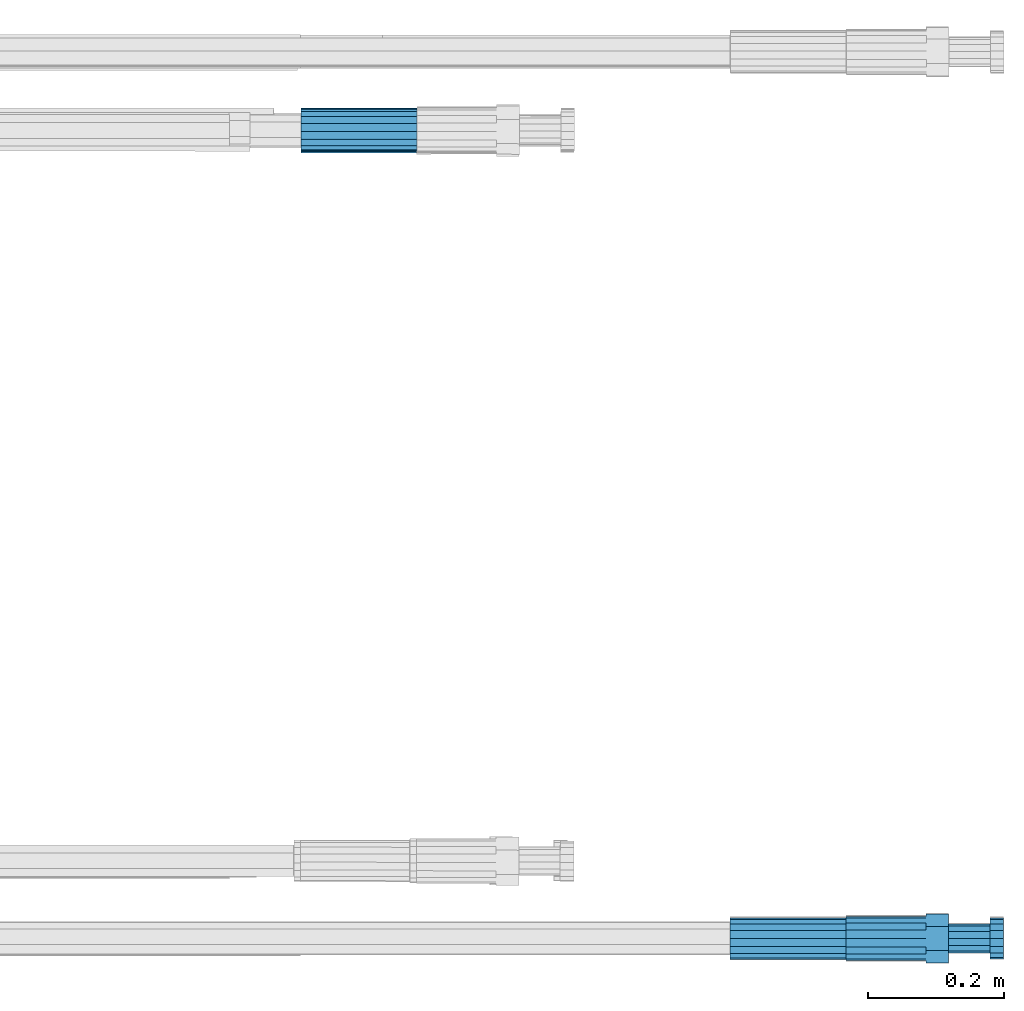
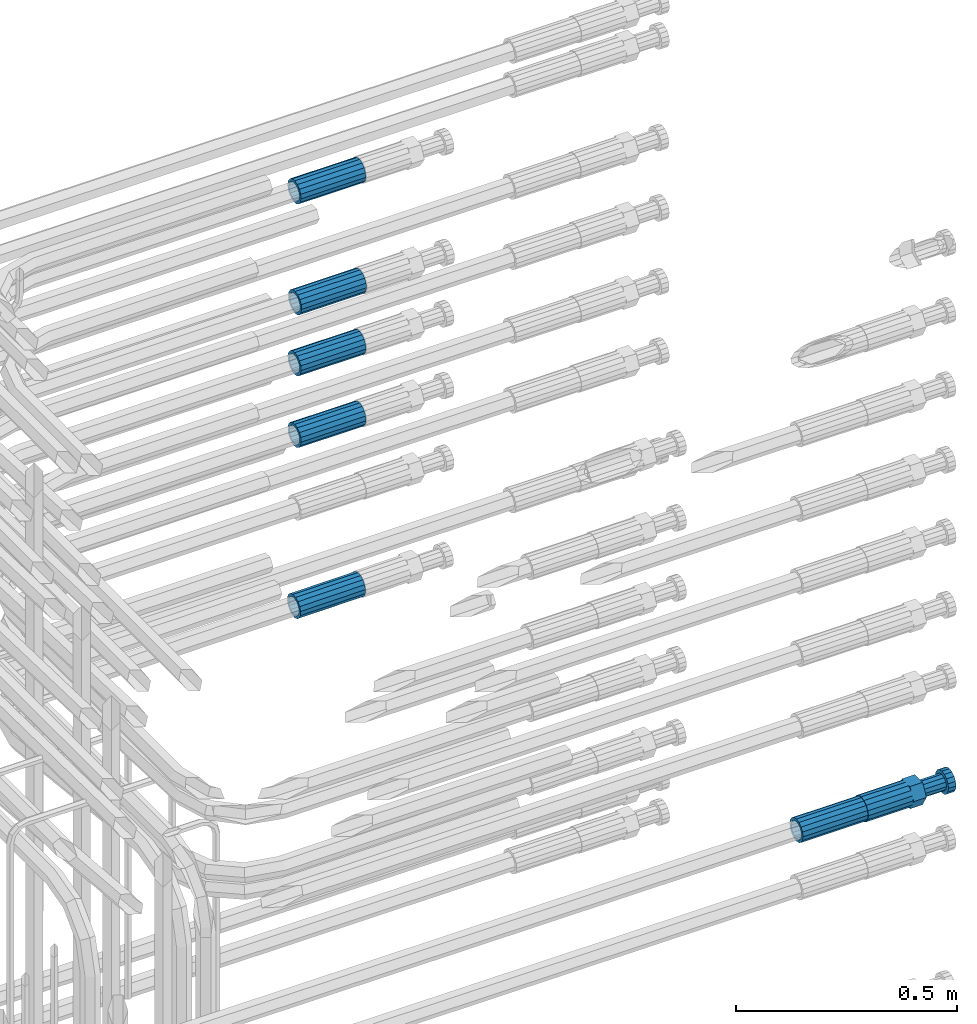
# One storey, part 107 of 177: 7 beams.
"""IFC2X3 building model written with IfcOpenShell, lengths in millimetres."""

from ifc_helpers import new_model, si_unit, frame, origin_with_axes, place, context, subcontext, project, spatial, faceted_brep, material, type_object, element, save


model = new_model("IFC2X3")

# Units and contexts
model_context_1 = context("Model", 3, precision=1e-05, world=origin_with_axes())
model_context_2 = context("Model", 3, precision=1e-05, world=origin_with_axes())
body_context = subcontext(model_context_2, "Body", "Model", "MODEL_VIEW")
ifc_project = project(units=[si_unit("LENGTHUNIT", "METRE", prefix="MILLI"), si_unit("AREAUNIT", "SQUARE_METRE"), si_unit("VOLUMEUNIT", "CUBIC_METRE"), si_unit("MASSUNIT", "GRAM", prefix="KILO"), si_unit("TIMEUNIT", "SECOND"), si_unit("PLANEANGLEUNIT", "RADIAN"), si_unit("SOLIDANGLEUNIT", "STERADIAN"), si_unit("THERMODYNAMICTEMPERATUREUNIT", "DEGREE_CELSIUS"), si_unit("LUMINOUSINTENSITYUNIT", "LUMEN")], contexts=[model_context_1])

# Site, building, storey
site_placement = place(None, origin_with_axes())
site = spatial("IfcSite", under=ifc_project, at=site_placement, CompositionType="ELEMENT")
building_placement = place(site_placement, origin_with_axes())
building = spatial("IfcBuilding", under=site, at=building_placement, Name="Undefined", CompositionType="ELEMENT")
storey_placement = place(building_placement, origin_with_axes())
storey = spatial("IfcBuildingStorey", under=building, at=storey_placement, Name="Undefined", CompositionType="ELEMENT", Elevation=0.0)

# Beams
ifc_material = material(Name="STEEL/S275")
beam_type_1 = type_object("IfcBeamType", PredefinedType="NOTDEFINED")
beam_1_placement = place(storey_placement, frame((2038719.59065702, 6206286.93900969, 19591.9562850024), z_axis=(0.00670106354495501, -0.109590881040318, -0.993954191369086), x_axis=(0.999977413945273, 0.000220438997534024, 0.00671736599963343)))
element("IfcBeam", 1, at=beam_1_placement, inside=storey, type_object=beam_type_1, material=ifc_material, Name="AG40N", context=body_context, shape_type="Brep", body=[
    faceted_brep([(0.0, -23.5000000001164, -9.31322574615479e-10), (0.0, -21.7111690140155, 8.99306066054851), (170.0, -21.7111690140155, 8.99306066054851), (170.0, -23.5, 0.0), (0.0, -16.6170093578839, 16.6170093575493), (170.0, -16.6170093578839, 16.6170093575493), (0.0, -8.99306066057943, 21.7111690137535), (170.0, -8.99306066057943, 21.7111690137535), (0.0, 1.16415321826935e-10, 23.5), (170.0, 0.0, 23.5), (0.0, 8.99306066057943, 21.7111690137535), (170.0, 8.99306066057943, 21.7111690137535), (0.0, 16.6170093578839, 16.6170093575493), (170.0, 16.6170093578839, 16.6170093575493), (0.0, 21.7111690140155, 8.99306066054851), (170.0, 21.7111690140155, 8.99306066054851), (0.0, 23.5000000001164, -9.31322574615479e-10), (170.0, 23.5, 0.0), (0.0, 21.7111690140155, -8.99306066054851), (170.0, 21.7111690140155, -8.99306066054851), (0.0, 16.6170093578839, -16.6170093575493), (170.0, 16.6170093578839, -16.6170093575493), (0.0, 8.99306066057943, -21.7111690137535), (170.0, 8.99306066057943, -21.7111690137535), (0.0, 1.16415321826935e-10, -23.5000000009313), (170.0, 0.0, -23.5), (0.0, -8.99306066057943, -21.7111690137535), (170.0, -8.99306066057943, -21.7111690137535), (0.0, -16.6170093578839, -16.6170093575493), (170.0, -16.6170093578839, -16.6170093575493), (0.0, -21.7111690140155, -8.99306066054851), (170.0, -21.7111690140155, -8.99306066054851), (0.0, -30.5, 0.0), (0.0, -28.1783257415937, -11.6718446873128), (170.0, -28.1783257415937, -11.6718446873128), (170.0, -30.5, 0.0), (0.0, -21.5667568261888, -21.5667568258941), (170.0, -21.5667568261888, -21.5667568258941), (0.0, -11.6718446871346, -28.1783257415518), (170.0, -11.6718446871346, -28.1783257415518), (0.0, 0.0, -30.5), (170.0, 0.0, -30.5), (0.0, 11.6718446871346, -28.1783257415518), (170.0, 11.6718446871346, -28.1783257415518), (0.0, 21.5667568261888, -21.5667568258941), (170.0, 21.5667568261888, -21.5667568258941), (0.0, 28.1783257415937, -11.6718446873128), (170.0, 28.1783257415937, -11.6718446873128), (0.0, 30.5, 0.0), (170.0, 30.5, 0.0), (0.0, 28.1783257415937, 11.6718446873128), (170.0, 28.1783257415937, 11.6718446873128), (0.0, 21.5667568261888, 21.5667568258941), (170.0, 21.5667568261888, 21.5667568258941), (0.0, 11.6718446871346, 28.1783257415518), (170.0, 11.6718446871346, 28.1783257415518), (0.0, 0.0, 30.5), (170.0, 0.0, 30.5), (0.0, -11.6718446871346, 28.1783257415518), (170.0, -11.6718446871346, 28.1783257415518), (0.0, -21.5667568261888, 21.5667568258941), (170.0, -21.5667568261888, 21.5667568258941), (0.0, -28.1783257415937, 11.6718446873128), (170.0, -28.1783257415937, 11.6718446873128)], [[[0, 1, 2, 3]], [[1, 4, 5, 2]], [[4, 6, 7, 5]], [[6, 8, 9, 7]], [[8, 10, 11, 9]], [[10, 12, 13, 11]], [[12, 14, 15, 13]], [[14, 16, 17, 15]], [[16, 18, 19, 17]], [[18, 20, 21, 19]], [[20, 22, 23, 21]], [[22, 24, 25, 23]], [[24, 26, 27, 25]], [[26, 28, 29, 27]], [[28, 30, 31, 29]], [[30, 0, 3, 31]], [[32, 33, 34, 35]], [[33, 36, 37, 34]], [[36, 38, 39, 37]], [[38, 40, 41, 39]], [[40, 42, 43, 41]], [[42, 44, 45, 43]], [[44, 46, 47, 45]], [[46, 48, 49, 47]], [[48, 50, 51, 49]], [[50, 52, 53, 51]], [[52, 54, 55, 53]], [[54, 56, 57, 55]], [[56, 58, 59, 57]], [[58, 60, 61, 59]], [[60, 62, 63, 61]], [[62, 32, 35, 63]], [[37, 39, 41, 43, 45, 47, 49, 51, 53, 55, 57, 59, 61, 63, 35, 34], [5, 7, 9, 11, 13, 15, 17, 19, 21, 23, 25, 27, 29, 31, 3, 2]], [[62, 60, 58, 56, 54, 52, 50, 48, 46, 44, 42, 40, 38, 36, 33, 32], [30, 28, 26, 24, 22, 20, 18, 16, 14, 12, 10, 8, 6, 4, 1, 0]]]),
])
beam_2_placement = place(storey_placement, frame((2038719.51807103, 6206284.99452423, 20740.8782264994), z_axis=(0.000401818353682753, 0.0766636489927762, -0.997056930904712), x_axis=(0.99999965876512, -0.000750492002025629, 0.000345298999912415)))
element("IfcBeam", 2, at=beam_2_placement, inside=storey, type_object=beam_type_1, material=ifc_material, Name="AG40N", context=body_context, shape_type="Brep", body=[
    faceted_brep([(0.0, -23.5000000001164, -9.31322574615479e-10), (0.0, -21.7111690140155, 8.99306066054851), (170.0, -21.7111690140155, 8.99306066054851), (170.0, -23.5, 0.0), (0.0, -16.6170093578839, 16.6170093575493), (170.0, -16.6170093578839, 16.6170093575493), (0.0, -8.99306066057943, 21.7111690137535), (170.0, -8.99306066057943, 21.7111690137535), (0.0, 1.16415321826935e-10, 23.5), (170.0, 0.0, 23.5), (0.0, 8.99306066057943, 21.7111690137535), (170.0, 8.99306066057943, 21.7111690137535), (0.0, 16.6170093578839, 16.6170093575493), (170.0, 16.6170093578839, 16.6170093575493), (0.0, 21.7111690140155, 8.99306066054851), (170.0, 21.7111690140155, 8.99306066054851), (0.0, 23.5000000001164, -9.31322574615479e-10), (170.0, 23.5, 0.0), (0.0, 21.7111690140155, -8.99306066054851), (170.0, 21.7111690140155, -8.99306066054851), (0.0, 16.6170093578839, -16.6170093575493), (170.0, 16.6170093578839, -16.6170093575493), (0.0, 8.99306066057943, -21.7111690137535), (170.0, 8.99306066057943, -21.7111690137535), (0.0, 1.16415321826935e-10, -23.5000000009313), (170.0, 0.0, -23.5), (0.0, -8.99306066057943, -21.7111690137535), (170.0, -8.99306066057943, -21.7111690137535), (0.0, -16.6170093578839, -16.6170093575493), (170.0, -16.6170093578839, -16.6170093575493), (0.0, -21.7111690140155, -8.99306066054851), (170.0, -21.7111690140155, -8.99306066054851), (0.0, -30.5, 0.0), (0.0, -28.1783257415937, -11.6718446873128), (170.0, -28.1783257415937, -11.6718446873128), (170.0, -30.5, 0.0), (0.0, -21.5667568261888, -21.5667568258941), (170.0, -21.5667568261888, -21.5667568258941), (0.0, -11.6718446871346, -28.1783257415518), (170.0, -11.6718446871346, -28.1783257415518), (0.0, 0.0, -30.5), (170.0, 0.0, -30.5), (0.0, 11.6718446871346, -28.1783257415518), (170.0, 11.6718446871346, -28.1783257415518), (0.0, 21.5667568261888, -21.5667568258941), (170.0, 21.5667568261888, -21.5667568258941), (0.0, 28.1783257415937, -11.6718446873128), (170.0, 28.1783257415937, -11.6718446873128), (0.0, 30.5, 0.0), (170.0, 30.5, 0.0), (0.0, 28.1783257415937, 11.6718446873128), (170.0, 28.1783257415937, 11.6718446873128), (0.0, 21.5667568261888, 21.5667568258941), (170.0, 21.5667568261888, 21.5667568258941), (0.0, 11.6718446871346, 28.1783257415518), (170.0, 11.6718446871346, 28.1783257415518), (0.0, 0.0, 30.5), (170.0, 0.0, 30.5), (0.0, -11.6718446871346, 28.1783257415518), (170.0, -11.6718446871346, 28.1783257415518), (0.0, -21.5667568261888, 21.5667568258941), (170.0, -21.5667568261888, 21.5667568258941), (0.0, -28.1783257415937, 11.6718446873128), (170.0, -28.1783257415937, 11.6718446873128)], [[[0, 1, 2, 3]], [[1, 4, 5, 2]], [[4, 6, 7, 5]], [[6, 8, 9, 7]], [[8, 10, 11, 9]], [[10, 12, 13, 11]], [[12, 14, 15, 13]], [[14, 16, 17, 15]], [[16, 18, 19, 17]], [[18, 20, 21, 19]], [[20, 22, 23, 21]], [[22, 24, 25, 23]], [[24, 26, 27, 25]], [[26, 28, 29, 27]], [[28, 30, 31, 29]], [[30, 0, 3, 31]], [[32, 33, 34, 35]], [[33, 36, 37, 34]], [[36, 38, 39, 37]], [[38, 40, 41, 39]], [[40, 42, 43, 41]], [[42, 44, 45, 43]], [[44, 46, 47, 45]], [[46, 48, 49, 47]], [[48, 50, 51, 49]], [[50, 52, 53, 51]], [[52, 54, 55, 53]], [[54, 56, 57, 55]], [[56, 58, 59, 57]], [[58, 60, 61, 59]], [[60, 62, 63, 61]], [[62, 32, 35, 63]], [[37, 39, 41, 43, 45, 47, 49, 51, 53, 55, 57, 59, 61, 63, 35, 34], [5, 7, 9, 11, 13, 15, 17, 19, 21, 23, 25, 27, 29, 31, 3, 2]], [[62, 60, 58, 56, 54, 52, 50, 48, 46, 44, 42, 40, 38, 36, 33, 32], [30, 28, 26, 24, 22, 20, 18, 16, 14, 12, 10, 8, 6, 4, 1, 0]]]),
])
beam_3_placement = place(storey_placement, frame((2038719.51584447, 6206284.25478352, 20067.1623282997), z_axis=(0.0, 0.0505929410066467, -0.998719357137078), x_axis=(1.0, 0.0, 0.0)))
element("IfcBeam", 3, at=beam_3_placement, inside=storey, type_object=beam_type_1, material=ifc_material, Name="AG40N", context=body_context, shape_type="Brep", body=[
    faceted_brep([(0.0, -23.5000000001164, -9.31322574615479e-10), (0.0, -21.7111690140155, 8.99306066054851), (170.0, -21.7111690140155, 8.99306066054851), (170.0, -23.5, 0.0), (0.0, -16.6170093578839, 16.6170093575493), (170.0, -16.6170093578839, 16.6170093575493), (0.0, -8.99306066057943, 21.7111690137535), (170.0, -8.99306066057943, 21.7111690137535), (0.0, 1.16415321826935e-10, 23.5), (170.0, 0.0, 23.5), (0.0, 8.99306066057943, 21.7111690137535), (170.0, 8.99306066057943, 21.7111690137535), (0.0, 16.6170093578839, 16.6170093575493), (170.0, 16.6170093578839, 16.6170093575493), (0.0, 21.7111690140155, 8.99306066054851), (170.0, 21.7111690140155, 8.99306066054851), (0.0, 23.5000000001164, -9.31322574615479e-10), (170.0, 23.5, 0.0), (0.0, 21.7111690140155, -8.99306066054851), (170.0, 21.7111690140155, -8.99306066054851), (0.0, 16.6170093578839, -16.6170093575493), (170.0, 16.6170093578839, -16.6170093575493), (0.0, 8.99306066057943, -21.7111690137535), (170.0, 8.99306066057943, -21.7111690137535), (0.0, 1.16415321826935e-10, -23.5000000009313), (170.0, 0.0, -23.5), (0.0, -8.99306066057943, -21.7111690137535), (170.0, -8.99306066057943, -21.7111690137535), (0.0, -16.6170093578839, -16.6170093575493), (170.0, -16.6170093578839, -16.6170093575493), (0.0, -21.7111690140155, -8.99306066054851), (170.0, -21.7111690140155, -8.99306066054851), (0.0, -30.5, 0.0), (0.0, -28.1783257415937, -11.6718446873128), (170.0, -28.1783257415937, -11.6718446873128), (170.0, -30.5, 0.0), (0.0, -21.5667568261888, -21.5667568258941), (170.0, -21.5667568261888, -21.5667568258941), (0.0, -11.6718446871346, -28.1783257415518), (170.0, -11.6718446871346, -28.1783257415518), (0.0, 0.0, -30.5), (170.0, 0.0, -30.5), (0.0, 11.6718446871346, -28.1783257415518), (170.0, 11.6718446871346, -28.1783257415518), (0.0, 21.5667568261888, -21.5667568258941), (170.0, 21.5667568261888, -21.5667568258941), (0.0, 28.1783257415937, -11.6718446873128), (170.0, 28.1783257415937, -11.6718446873128), (0.0, 30.5, 0.0), (170.0, 30.5, 0.0), (0.0, 28.1783257415937, 11.6718446873128), (170.0, 28.1783257415937, 11.6718446873128), (0.0, 21.5667568261888, 21.5667568258941), (170.0, 21.5667568261888, 21.5667568258941), (0.0, 11.6718446871346, 28.1783257415518), (170.0, 11.6718446871346, 28.1783257415518), (0.0, 0.0, 30.5), (170.0, 0.0, 30.5), (0.0, -11.6718446871346, 28.1783257415518), (170.0, -11.6718446871346, 28.1783257415518), (0.0, -21.5667568261888, 21.5667568258941), (170.0, -21.5667568261888, 21.5667568258941), (0.0, -28.1783257415937, 11.6718446873128), (170.0, -28.1783257415937, 11.6718446873128)], [[[0, 1, 2, 3]], [[1, 4, 5, 2]], [[4, 6, 7, 5]], [[6, 8, 9, 7]], [[8, 10, 11, 9]], [[10, 12, 13, 11]], [[12, 14, 15, 13]], [[14, 16, 17, 15]], [[16, 18, 19, 17]], [[18, 20, 21, 19]], [[20, 22, 23, 21]], [[22, 24, 25, 23]], [[24, 26, 27, 25]], [[26, 28, 29, 27]], [[28, 30, 31, 29]], [[30, 0, 3, 31]], [[32, 33, 34, 35]], [[33, 36, 37, 34]], [[36, 38, 39, 37]], [[38, 40, 41, 39]], [[40, 42, 43, 41]], [[42, 44, 45, 43]], [[44, 46, 47, 45]], [[46, 48, 49, 47]], [[48, 50, 51, 49]], [[50, 52, 53, 51]], [[52, 54, 55, 53]], [[54, 56, 57, 55]], [[56, 58, 59, 57]], [[58, 60, 61, 59]], [[60, 62, 63, 61]], [[62, 32, 35, 63]], [[37, 39, 41, 43, 45, 47, 49, 51, 53, 55, 57, 59, 61, 63, 35, 34], [5, 7, 9, 11, 13, 15, 17, 19, 21, 23, 25, 27, 29, 31, 3, 2]], [[62, 60, 58, 56, 54, 52, 50, 48, 46, 44, 42, 40, 38, 36, 33, 32], [30, 28, 26, 24, 22, 20, 18, 16, 14, 12, 10, 8, 6, 4, 1, 0]]]),
])
beam_4_placement = place(storey_placement, frame((2038719.27268514, 6206281.63885606, 20436.1870435576), z_axis=(0.00101999019715003, 0.0419084800034758, -0.999120933082575), x_axis=(0.999999429542936, 0.000274046000794836, 0.00103238199952223)))
element("IfcBeam", 4, at=beam_4_placement, inside=storey, type_object=beam_type_1, material=ifc_material, Name="AG40N", context=body_context, shape_type="Brep", body=[
    faceted_brep([(0.0, -23.5000000001164, -9.31322574615479e-10), (0.0, -21.7111690140155, 8.99306066054851), (170.0, -21.7111690140155, 8.99306066054851), (170.0, -23.5, 0.0), (0.0, -16.6170093578839, 16.6170093575493), (170.0, -16.6170093578839, 16.6170093575493), (0.0, -8.99306066057943, 21.7111690137535), (170.0, -8.99306066057943, 21.7111690137535), (0.0, 1.16415321826935e-10, 23.5), (170.0, 0.0, 23.5), (0.0, 8.99306066057943, 21.7111690137535), (170.0, 8.99306066057943, 21.7111690137535), (0.0, 16.6170093578839, 16.6170093575493), (170.0, 16.6170093578839, 16.6170093575493), (0.0, 21.7111690140155, 8.99306066054851), (170.0, 21.7111690140155, 8.99306066054851), (0.0, 23.5000000001164, -9.31322574615479e-10), (170.0, 23.5, 0.0), (0.0, 21.7111690140155, -8.99306066054851), (170.0, 21.7111690140155, -8.99306066054851), (0.0, 16.6170093578839, -16.6170093575493), (170.0, 16.6170093578839, -16.6170093575493), (0.0, 8.99306066057943, -21.7111690137535), (170.0, 8.99306066057943, -21.7111690137535), (0.0, 1.16415321826935e-10, -23.5000000009313), (170.0, 0.0, -23.5), (0.0, -8.99306066057943, -21.7111690137535), (170.0, -8.99306066057943, -21.7111690137535), (0.0, -16.6170093578839, -16.6170093575493), (170.0, -16.6170093578839, -16.6170093575493), (0.0, -21.7111690140155, -8.99306066054851), (170.0, -21.7111690140155, -8.99306066054851), (0.0, -30.5, 0.0), (0.0, -28.1783257415937, -11.6718446873128), (170.0, -28.1783257415937, -11.6718446873128), (170.0, -30.5, 0.0), (0.0, -21.5667568261888, -21.5667568258941), (170.0, -21.5667568261888, -21.5667568258941), (0.0, -11.6718446871346, -28.1783257415518), (170.0, -11.6718446871346, -28.1783257415518), (0.0, 0.0, -30.5), (170.0, 0.0, -30.5), (0.0, 11.6718446871346, -28.1783257415518), (170.0, 11.6718446871346, -28.1783257415518), (0.0, 21.5667568261888, -21.5667568258941), (170.0, 21.5667568261888, -21.5667568258941), (0.0, 28.1783257415937, -11.6718446873128), (170.0, 28.1783257415937, -11.6718446873128), (0.0, 30.5, 0.0), (170.0, 30.5, 0.0), (0.0, 28.1783257415937, 11.6718446873128), (170.0, 28.1783257415937, 11.6718446873128), (0.0, 21.5667568261888, 21.5667568258941), (170.0, 21.5667568261888, 21.5667568258941), (0.0, 11.6718446871346, 28.1783257415518), (170.0, 11.6718446871346, 28.1783257415518), (0.0, 0.0, 30.5), (170.0, 0.0, 30.5), (0.0, -11.6718446871346, 28.1783257415518), (170.0, -11.6718446871346, 28.1783257415518), (0.0, -21.5667568261888, 21.5667568258941), (170.0, -21.5667568261888, 21.5667568258941), (0.0, -28.1783257415937, 11.6718446873128), (170.0, -28.1783257415937, 11.6718446873128)], [[[0, 1, 2, 3]], [[1, 4, 5, 2]], [[4, 6, 7, 5]], [[6, 8, 9, 7]], [[8, 10, 11, 9]], [[10, 12, 13, 11]], [[12, 14, 15, 13]], [[14, 16, 17, 15]], [[16, 18, 19, 17]], [[18, 20, 21, 19]], [[20, 22, 23, 21]], [[22, 24, 25, 23]], [[24, 26, 27, 25]], [[26, 28, 29, 27]], [[28, 30, 31, 29]], [[30, 0, 3, 31]], [[32, 33, 34, 35]], [[33, 36, 37, 34]], [[36, 38, 39, 37]], [[38, 40, 41, 39]], [[40, 42, 43, 41]], [[42, 44, 45, 43]], [[44, 46, 47, 45]], [[46, 48, 49, 47]], [[48, 50, 51, 49]], [[50, 52, 53, 51]], [[52, 54, 55, 53]], [[54, 56, 57, 55]], [[56, 58, 59, 57]], [[58, 60, 61, 59]], [[60, 62, 63, 61]], [[62, 32, 35, 63]], [[37, 39, 41, 43, 45, 47, 49, 51, 53, 55, 57, 59, 61, 63, 35, 34], [5, 7, 9, 11, 13, 15, 17, 19, 21, 23, 25, 27, 29, 31, 3, 2]], [[62, 60, 58, 56, 54, 52, 50, 48, 46, 44, 42, 40, 38, 36, 33, 32], [30, 28, 26, 24, 22, 20, 18, 16, 14, 12, 10, 8, 6, 4, 1, 0]]]),
])
beam_5_placement = place(storey_placement, frame((2038719.51584447, 6206284.40860386, 20265.444592741), z_axis=(0.0, 0.0523359569851309, -0.998629534715678), x_axis=(1.0, 0.0, 0.0)))
element("IfcBeam", 5, at=beam_5_placement, inside=storey, type_object=beam_type_1, material=ifc_material, Name="AG40N", context=body_context, shape_type="Brep", body=[
    faceted_brep([(0.0, -23.5000000001164, -9.31322574615479e-10), (0.0, -21.7111690140155, 8.99306066054851), (170.0, -21.7111690140155, 8.99306066054851), (170.0, -23.5, 0.0), (0.0, -16.6170093578839, 16.6170093575493), (170.0, -16.6170093578839, 16.6170093575493), (0.0, -8.99306066057943, 21.7111690137535), (170.0, -8.99306066057943, 21.7111690137535), (0.0, 1.16415321826935e-10, 23.5), (170.0, 0.0, 23.5), (0.0, 8.99306066057943, 21.7111690137535), (170.0, 8.99306066057943, 21.7111690137535), (0.0, 16.6170093578839, 16.6170093575493), (170.0, 16.6170093578839, 16.6170093575493), (0.0, 21.7111690140155, 8.99306066054851), (170.0, 21.7111690140155, 8.99306066054851), (0.0, 23.5000000001164, -9.31322574615479e-10), (170.0, 23.5, 0.0), (0.0, 21.7111690140155, -8.99306066054851), (170.0, 21.7111690140155, -8.99306066054851), (0.0, 16.6170093578839, -16.6170093575493), (170.0, 16.6170093578839, -16.6170093575493), (0.0, 8.99306066057943, -21.7111690137535), (170.0, 8.99306066057943, -21.7111690137535), (0.0, 1.16415321826935e-10, -23.5000000009313), (170.0, 0.0, -23.5), (0.0, -8.99306066057943, -21.7111690137535), (170.0, -8.99306066057943, -21.7111690137535), (0.0, -16.6170093578839, -16.6170093575493), (170.0, -16.6170093578839, -16.6170093575493), (0.0, -21.7111690140155, -8.99306066054851), (170.0, -21.7111690140155, -8.99306066054851), (0.0, -30.5, 0.0), (0.0, -28.1783257415937, -11.6718446873128), (170.0, -28.1783257415937, -11.6718446873128), (170.0, -30.5, 0.0), (0.0, -21.5667568261888, -21.5667568258941), (170.0, -21.5667568261888, -21.5667568258941), (0.0, -11.6718446871346, -28.1783257415518), (170.0, -11.6718446871346, -28.1783257415518), (0.0, 0.0, -30.5), (170.0, 0.0, -30.5), (0.0, 11.6718446871346, -28.1783257415518), (170.0, 11.6718446871346, -28.1783257415518), (0.0, 21.5667568261888, -21.5667568258941), (170.0, 21.5667568261888, -21.5667568258941), (0.0, 28.1783257415937, -11.6718446873128), (170.0, 28.1783257415937, -11.6718446873128), (0.0, 30.5, 0.0), (170.0, 30.5, 0.0), (0.0, 28.1783257415937, 11.6718446873128), (170.0, 28.1783257415937, 11.6718446873128), (0.0, 21.5667568261888, 21.5667568258941), (170.0, 21.5667568261888, 21.5667568258941), (0.0, 11.6718446871346, 28.1783257415518), (170.0, 11.6718446871346, 28.1783257415518), (0.0, 0.0, 30.5), (170.0, 0.0, 30.5), (0.0, -11.6718446871346, 28.1783257415518), (170.0, -11.6718446871346, 28.1783257415518), (0.0, -21.5667568261888, 21.5667568258941), (170.0, -21.5667568261888, 21.5667568258941), (0.0, -28.1783257415937, 11.6718446873128), (170.0, -28.1783257415937, 11.6718446873128)], [[[0, 1, 2, 3]], [[1, 4, 5, 2]], [[4, 6, 7, 5]], [[6, 8, 9, 7]], [[8, 10, 11, 9]], [[10, 12, 13, 11]], [[12, 14, 15, 13]], [[14, 16, 17, 15]], [[16, 18, 19, 17]], [[18, 20, 21, 19]], [[20, 22, 23, 21]], [[22, 24, 25, 23]], [[24, 26, 27, 25]], [[26, 28, 29, 27]], [[28, 30, 31, 29]], [[30, 0, 3, 31]], [[32, 33, 34, 35]], [[33, 36, 37, 34]], [[36, 38, 39, 37]], [[38, 40, 41, 39]], [[40, 42, 43, 41]], [[42, 44, 45, 43]], [[44, 46, 47, 45]], [[46, 48, 49, 47]], [[48, 50, 51, 49]], [[50, 52, 53, 51]], [[52, 54, 55, 53]], [[54, 56, 57, 55]], [[56, 58, 59, 57]], [[58, 60, 61, 59]], [[60, 62, 63, 61]], [[62, 32, 35, 63]], [[37, 39, 41, 43, 45, 47, 49, 51, 53, 55, 57, 59, 61, 63, 35, 34], [5, 7, 9, 11, 13, 15, 17, 19, 21, 23, 25, 27, 29, 31, 3, 2]], [[62, 60, 58, 56, 54, 52, 50, 48, 46, 44, 42, 40, 38, 36, 33, 32], [30, 28, 26, 24, 22, 20, 18, 16, 14, 12, 10, 8, 6, 4, 1, 0]]]),
])
beam_6_placement = place(storey_placement, frame((2039349.02228821, 6205098.98588362, 19471.9867998314), z_axis=(0.0, 0.0, -1.0), x_axis=(1.0, 0.0, 0.0)))
element("IfcBeam", 6, at=beam_6_placement, inside=storey, type_object=beam_type_1, material=ifc_material, Name="AG40N", context=body_context, shape_type="Brep", body=[
    faceted_brep([(0.0, -23.5000000001164, -9.31322574615479e-10), (0.0, -21.7111690140155, 8.99306066054851), (170.0, -21.7111690140155, 8.99306066054851), (170.0, -23.5, 0.0), (0.0, -16.6170093578839, 16.6170093575493), (170.0, -16.6170093578839, 16.6170093575493), (0.0, -8.99306066057943, 21.7111690137535), (170.0, -8.99306066057943, 21.7111690137535), (0.0, 1.16415321826935e-10, 23.5), (170.0, 0.0, 23.5), (0.0, 8.99306066057943, 21.7111690137535), (170.0, 8.99306066057943, 21.7111690137535), (0.0, 16.6170093578839, 16.6170093575493), (170.0, 16.6170093578839, 16.6170093575493), (0.0, 21.7111690140155, 8.99306066054851), (170.0, 21.7111690140155, 8.99306066054851), (0.0, 23.5000000001164, -9.31322574615479e-10), (170.0, 23.5, 0.0), (0.0, 21.7111690140155, -8.99306066054851), (170.0, 21.7111690140155, -8.99306066054851), (0.0, 16.6170093578839, -16.6170093575493), (170.0, 16.6170093578839, -16.6170093575493), (0.0, 8.99306066057943, -21.7111690137535), (170.0, 8.99306066057943, -21.7111690137535), (0.0, 1.16415321826935e-10, -23.5000000009313), (170.0, 0.0, -23.5), (0.0, -8.99306066057943, -21.7111690137535), (170.0, -8.99306066057943, -21.7111690137535), (0.0, -16.6170093578839, -16.6170093575493), (170.0, -16.6170093578839, -16.6170093575493), (0.0, -21.7111690140155, -8.99306066054851), (170.0, -21.7111690140155, -8.99306066054851), (0.0, -30.5, 0.0), (0.0, -28.1783257415937, -11.6718446873128), (170.0, -28.1783257415937, -11.6718446873128), (170.0, -30.5, 0.0), (0.0, -21.5667568261888, -21.5667568258941), (170.0, -21.5667568261888, -21.5667568258941), (0.0, -11.6718446871346, -28.1783257415518), (170.0, -11.6718446871346, -28.1783257415518), (0.0, 0.0, -30.5), (170.0, 0.0, -30.5), (0.0, 11.6718446871346, -28.1783257415518), (170.0, 11.6718446871346, -28.1783257415518), (0.0, 21.5667568261888, -21.5667568258941), (170.0, 21.5667568261888, -21.5667568258941), (0.0, 28.1783257415937, -11.6718446873128), (170.0, 28.1783257415937, -11.6718446873128), (0.0, 30.5, 0.0), (170.0, 30.5, 0.0), (0.0, 28.1783257415937, 11.6718446873128), (170.0, 28.1783257415937, 11.6718446873128), (0.0, 21.5667568261888, 21.5667568258941), (170.0, 21.5667568261888, 21.5667568258941), (0.0, 11.6718446871346, 28.1783257415518), (170.0, 11.6718446871346, 28.1783257415518), (0.0, 0.0, 30.5), (170.0, 0.0, 30.5), (0.0, -11.6718446871346, 28.1783257415518), (170.0, -11.6718446871346, 28.1783257415518), (0.0, -21.5667568261888, 21.5667568258941), (170.0, -21.5667568261888, 21.5667568258941), (0.0, -28.1783257415937, 11.6718446873128), (170.0, -28.1783257415937, 11.6718446873128)], [[[0, 1, 2, 3]], [[1, 4, 5, 2]], [[4, 6, 7, 5]], [[6, 8, 9, 7]], [[8, 10, 11, 9]], [[10, 12, 13, 11]], [[12, 14, 15, 13]], [[14, 16, 17, 15]], [[16, 18, 19, 17]], [[18, 20, 21, 19]], [[20, 22, 23, 21]], [[22, 24, 25, 23]], [[24, 26, 27, 25]], [[26, 28, 29, 27]], [[28, 30, 31, 29]], [[30, 0, 3, 31]], [[32, 33, 34, 35]], [[33, 36, 37, 34]], [[36, 38, 39, 37]], [[38, 40, 41, 39]], [[40, 42, 43, 41]], [[42, 44, 45, 43]], [[44, 46, 47, 45]], [[46, 48, 49, 47]], [[48, 50, 51, 49]], [[50, 52, 53, 51]], [[52, 54, 55, 53]], [[54, 56, 57, 55]], [[56, 58, 59, 57]], [[58, 60, 61, 59]], [[60, 62, 63, 61]], [[62, 32, 35, 63]], [[37, 39, 41, 43, 45, 47, 49, 51, 53, 55, 57, 59, 61, 63, 35, 34], [5, 7, 9, 11, 13, 15, 17, 19, 21, 23, 25, 27, 29, 31, 3, 2]], [[62, 60, 58, 56, 54, 52, 50, 48, 46, 44, 42, 40, 38, 36, 33, 32], [30, 28, 26, 24, 22, 20, 18, 16, 14, 12, 10, 8, 6, 4, 1, 0]]]),
])
beam_type_2 = type_object("IfcBeamType", Name="ROD65", PredefinedType="NOTDEFINED")
beam_7_placement = place(storey_placement, frame((2039519.02228821, 6205098.98588362, 19471.9867998312), z_axis=(0.0, 0.0, -1.0), x_axis=(1.0, 0.0, 0.0)))
element("IfcBeam", 7, at=beam_7_placement, inside=storey, type_object=beam_type_2, material=ifc_material, Name="AGB40", ObjectType="ROD65", context=body_context, shape_type="Brep", body=[
    faceted_brep([(117.0, 8.17543110251427, 30.873805644922), (117.0, 17.8250000001863, 30.873805644922), (117.0, 22.0056958701462, 23.6326279877685), (117.0, 12.4372115517035, 30.0260848065373), (117.0, -17.8250000001863, 30.873805644922), (150.200000000186, -17.8250000001863, 30.873805644922), (150.200000000186, 17.8250000001863, 30.873805644922), (117.0, -8.17543110251427, 30.873805644922), (117.0, -12.4372115517035, 30.0260848065373), (117.0, -22.0056958701462, 23.6326279877685), (117.0, -35.6500000003725, 0.0), (150.200000000186, -35.6500000003725, 0.0), (117.0, -30.8443150008097, 8.32369058486074), (117.0, -32.5, 0.0), (117.0, -30.8443150008097, -8.32369058462791), (117.0, -17.8250000001863, -30.873805644922), (150.200000000186, -17.8250000001863, -30.873805644922), (117.0, -22.0056958701462, -23.6326279877685), (117.0, -12.4372115517035, -30.0260848065373), (117.0, -8.17543110251427, -30.873805644922), (117.0, 17.8250000001863, -30.873805644922), (150.200000000186, 17.8250000001863, -30.873805644922), (117.0, 8.17543110251427, -30.873805644922), (117.0, 22.0056958701462, -23.6326279877685), (117.0, 12.4372115517035, -30.0260848065373), (117.0, 35.6500000003725, 0.0), (150.200000000186, 35.6500000003725, 0.0), (117.0, 30.8443150008097, -8.32369058486074), (117.0, 30.8443150008097, 8.32369058462791), (117.0, 32.5, 0.0), (0.0, -22.9809703892097, 22.9809703885621), (0.0, -30.0260848058388, 12.4372115518636), (117.0, -30.0260848067701, 12.4372115519363), (117.0, -22.9809703882784, 22.9809703885112), (-2.3283064365387e-10, 22.9809703892097, -22.9809703885639), (-4.65661287307739e-10, 30.0260848077014, -12.4372115518672), (117.0, 30.0260848067701, -12.4372115519363), (117.0, 22.9809703882784, -22.9809703885112), (-2.3283064365387e-10, -30.0260848067701, -12.4372115518672), (-2.3283064365387e-10, -22.9809703892097, -22.9809703885621), (117.0, -22.9809703882784, -22.9809703885112), (117.0, -30.0260848067701, -12.4372115519363), (-2.3283064365387e-10, -12.4372115507722, 30.0260848066137), (-2.3283064365387e-10, 9.31322574615479e-10, 32.4999999999982), (-2.3283064365387e-10, 12.4372115526348, 30.0260848066137), (0.0, 22.9809703892097, 22.9809703885621), (-2.3283064365387e-10, 30.0260848077014, 12.4372115518636), (-2.3283064365387e-10, 32.5, 0.0), (-2.3283064365387e-10, 12.4372115526348, -30.0260848066173), (-2.3283064365387e-10, 9.31322574615479e-10, -32.5), (-2.3283064365387e-10, -12.4372115517035, -30.0260848066173), (-4.65661287307739e-10, -32.4999999990687, -1.81898940354586e-12), (117.0, 22.9809703882784, 22.9809703885112), (117.0, 30.0260848067701, 12.4372115519363), (117.0, 0.0, -32.5), (117.0, 0.0, 32.5), (150.200000000186, 10.5, -18.1865334794857), (150.200000000186, 0.0, -21.0), (150.200000000186, -10.5, -18.1865334794857), (150.200000000186, -18.18653347902, -10.5), (150.200000000186, -21.0, 0.0), (150.200000000186, -18.18653347902, 10.5), (150.200000000186, -10.5, 18.1865334794857), (150.200000000186, 0.0, 21.0), (150.200000000186, 10.5, 18.1865334794857), (150.200000000186, 18.18653347902, 10.5), (150.200000000186, 21.0, 0.0), (150.200000000186, 18.18653347902, -10.5), (210.980000000447, -18.18653347902, 10.5), (210.980000000447, -21.0, 0.0), (210.980000000447, -10.5, 18.1865334794857), (210.980000000447, 0.0, 21.0), (210.980000000447, 10.5, 18.1865334794857), (210.980000000447, 18.18653347902, 10.5), (210.980000000447, 21.0, 0.0), (210.980000000447, 18.18653347902, -10.5), (210.980000000447, 10.5, -18.1865334794857), (210.980000000447, 0.0, -21.0), (210.980000000447, -10.5, -18.1865334794857), (210.980000000447, -18.18653347902, -10.5), (211.001368442696, -27.7269937992096, -11.491116326768), (211.003082550167, -21.2238094303757, -21.223815418547), (231.002518367059, -21.2131944671273, -21.2132004550658), (231.000804259587, -27.7163788359612, -11.4805013632867), (211.001368440451, -11.4911085031927, -27.7269970395137), (231.000804257343, -11.4804935399443, -27.7163820760325), (210.996487071217, -0.0106065049767494, -30.0106107392348), (230.995922888109, 8.45827162265778e-06, -29.9999957757536), (210.989181586672, 11.46989420522, -27.7269970329944), (230.988617403564, 11.4805091684684, -27.7163820695132), (210.980564180623, 21.2025914648548, -21.2238154064398), (230.979999997515, 21.2132064281031, -21.2132004429586), (210.971946775022, 27.7057703435421, -11.4911163107026), (230.971382591913, 27.7163853067905, -11.4805013472214), (210.96464129175, 29.9893808094785, -0.0106149562634528), (230.964077108642, 29.9999957727268, 7.21774995326996e-09), (210.959759924415, 27.7057638689876, 11.4698863970116), (230.959195741307, 27.7163788322359, 11.4805013604928), (210.958045816944, 21.2025795001537, 21.2025854887906), (230.957481633835, 21.213194463402, 21.2132004522718), (210.95975992666, 11.4698785729706, 27.7057671097573), (230.959195743551, 11.480493536219, 27.7163820732385), (210.964641295894, -0.010623425245285, 29.9893808094785), (230.964077112785, -8.46199691295624e-06, 29.9999957729597), (210.971946780439, -11.4911241354421, 27.705767103238), (230.97138259733, -11.4805091721937, 27.7163820667192), (210.980564186488, -21.2238213950768, 21.2025854766835), (230.980000003379, -21.2132064318284, 21.2132004401647), (210.989181592089, -27.7270002737641, 11.4698863809463), (230.988617408981, -27.7163853105158, 11.4805013444275), (210.996487075361, -30.0106107397005, -0.0106149734929204), (230.995922892253, -29.9999957764521, -1.00117176771164e-08)], [[[0, 1, 2, 3]], [[4, 5, 6, 1, 0, 7]], [[4, 7, 8, 9]], [[10, 11, 5, 4, 9, 12]], [[10, 12, 13, 14]], [[15, 16, 11, 10, 14, 17]], [[15, 17, 18, 19]], [[20, 21, 16, 15, 19, 22]], [[23, 20, 22, 24]], [[25, 26, 21, 20, 23, 27]], [[28, 25, 27, 29]], [[30, 31, 32, 33]], [[34, 35, 36, 37]], [[38, 39, 40, 41]], [[31, 30, 42, 43, 44, 45, 46, 47, 35, 34, 48, 49, 50, 39, 38, 51]], [[46, 45, 52, 53]], [[29, 47, 46, 53, 28]], [[27, 36, 35, 47, 29]], [[23, 37, 36, 27]], [[24, 48, 34, 37, 23]], [[22, 54, 49, 48, 24]], [[19, 54, 22]], [[18, 50, 49, 54, 19]], [[17, 40, 39, 50, 18]], [[14, 41, 40, 17]], [[13, 51, 38, 41, 14]], [[12, 32, 31, 51, 13]], [[9, 33, 32, 12]], [[8, 42, 30, 33, 9]], [[7, 55, 43, 42, 8]], [[0, 55, 7]], [[3, 44, 43, 55, 0]], [[2, 52, 45, 44, 3]], [[28, 53, 52, 2]], [[1, 6, 26, 25, 28, 2]], [[5, 11, 16, 21, 26, 6], [56, 57, 58, 59, 60, 61, 62, 63, 64, 65, 66, 67]], [[68, 61, 60, 69]], [[70, 62, 61, 68]], [[71, 63, 62, 70]], [[72, 64, 63, 71]], [[73, 65, 64, 72]], [[74, 66, 65, 73]], [[75, 67, 66, 74]], [[76, 56, 67, 75]], [[77, 57, 56, 76]], [[78, 58, 57, 77]], [[79, 59, 58, 78]], [[69, 60, 59, 79]], [[80, 81, 82, 83]], [[81, 84, 85, 82]], [[84, 86, 87, 85]], [[86, 88, 89, 87]], [[88, 90, 91, 89]], [[90, 92, 93, 91]], [[92, 94, 95, 93]], [[94, 96, 97, 95]], [[96, 98, 99, 97]], [[98, 100, 101, 99]], [[100, 102, 103, 101]], [[102, 104, 105, 103]], [[104, 106, 107, 105]], [[106, 108, 109, 107]], [[108, 110, 111, 109]], [[82, 85, 87, 89, 91, 93, 95, 97, 99, 101, 103, 105, 107, 109, 111, 83]], [[110, 80, 83, 111]], [[108, 106, 104, 102, 100, 98, 96, 94, 92, 90, 88, 86, 84, 81, 80, 110], [75, 74, 73, 72, 71, 70, 68, 69, 79, 78, 77, 76]]]),
])

save(model, "model.ifc")
